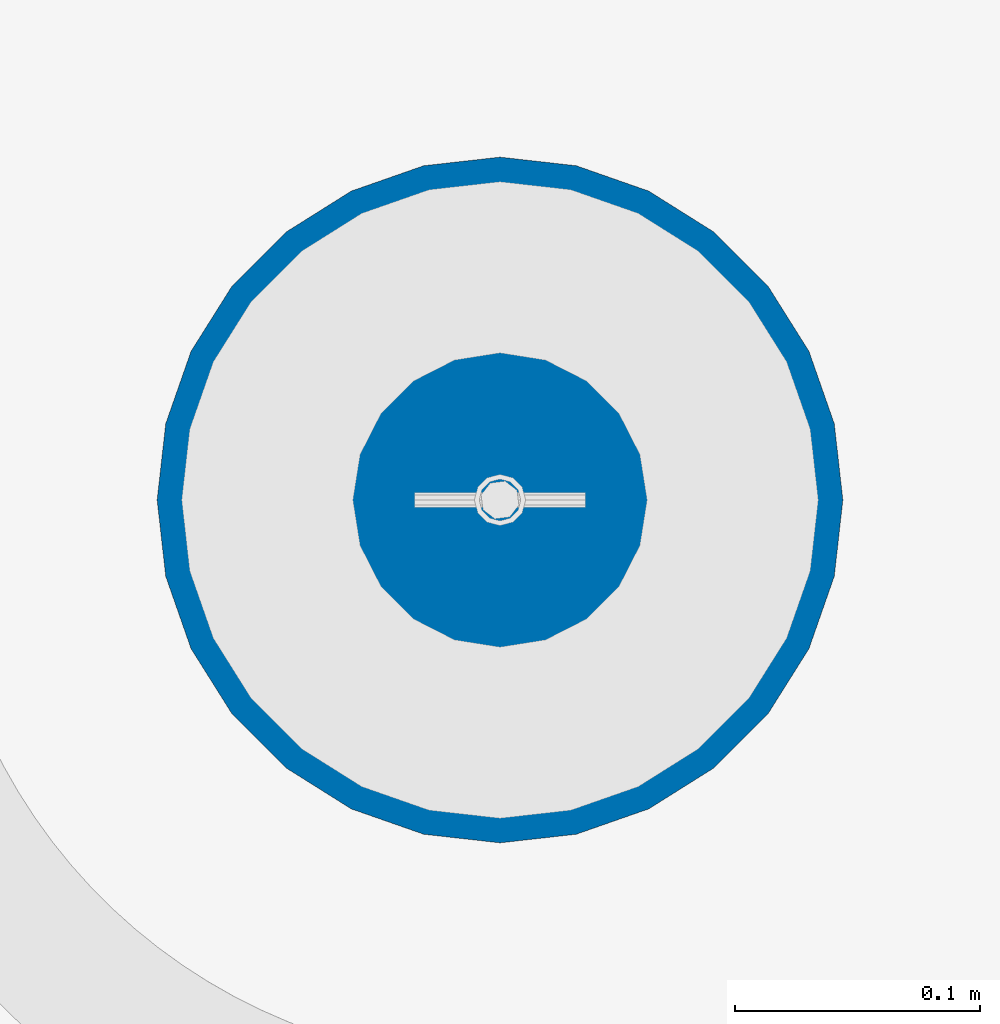
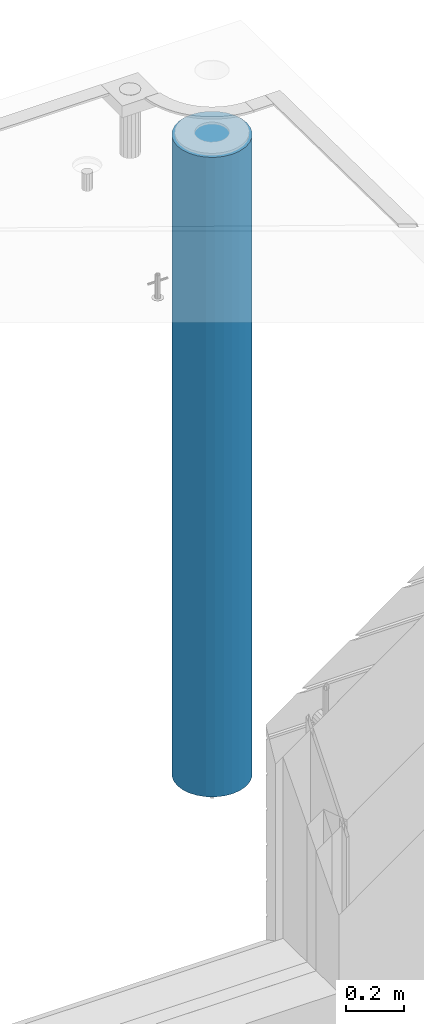
# One storey, part 7 of 350: 1 column, 1 element without a shape of its own.
"""IFC2X3 building model written with IfcOpenShell, lengths in millimetres."""

import ifcopenshell
import ifcopenshell.guid

model = None  # the IFC model being written
_history = None  # IfcOwnerHistory: only IFC2X3 demands one
_inside = {}  # id of a spatial element -> (the spatial element, [elements in it])
_under = {}  # id of a project, library or spatial element -> (it, [spatial elements below it])
_declared = {}  # id of a project -> (the project, [libraries it declares])
_typed = {}  # id of a type object -> (the type object, [elements of that type])
_made_of = {}  # id of a material, layer set ... -> (it, [elements and type objects made of it])


def new_model(schema):
    """Start an empty IFC model of exactly this schema.

    Asked for "IFC4X3", IfcOpenShell would pick the latest addendum, in which some entities
    have other attributes; the version numbers below select the first issue.
    IFC2X3 requires an IfcOwnerHistory on every rooted entity: one is made here for all.
    """
    global model, _history
    if schema == "IFC4X3":
        model = ifcopenshell.file(schema_version=(4, 3, 0, 0))
    else:
        model = ifcopenshell.file(schema=schema)
    _inside.clear()
    _under.clear()
    _declared.clear()
    _typed.clear()
    _made_of.clear()
    _history = None
    if model.schema == "IFC2X3":
        org = make("IfcOrganization", Name="unknown")
        user = make(
            "IfcPersonAndOrganization",
            ThePerson=make("IfcPerson", FamilyName="unknown"),
            TheOrganization=org,
        )
        app = make(
            "IfcApplication",
            ApplicationDeveloper=org,
            Version="unknown",
            ApplicationFullName="unknown",
            ApplicationIdentifier="unknown",
        )
        _history = make(
            "IfcOwnerHistory",
            OwningUser=user,
            OwningApplication=app,
            ChangeAction="ADDED",
            CreationDate=0,
        )
    return model


def make(cls, **values):
    """One entity of the class cls with the attributes given. An attribute that is None is left unset."""
    return model.create_entity(
        cls, **{name: value for name, value in values.items() if value is not None}
    )


def rooted(cls, **values):
    """An entity with a GlobalId (a new one), such as an element, a storey or a relation."""
    return make(cls, GlobalId=ifcopenshell.guid.new(), OwnerHistory=_history, **values)


def si_unit(unit_type, name, prefix=None):
    """IfcSIUnit, for example si_unit("LENGTHUNIT", "METRE", prefix="MILLI")."""
    return make("IfcSIUnit", UnitType=unit_type, Prefix=prefix, Name=name)


def assignment(units):
    """IfcUnitAssignment: the units of a project."""
    return None if units is None else make("IfcUnitAssignment", Units=units)


def point(xyz):
    """IfcCartesianPoint."""
    return None if xyz is None else make("IfcCartesianPoint", Coordinates=xyz)


def direction(xyz):
    """IfcDirection."""
    return None if xyz is None else make("IfcDirection", DirectionRatios=xyz)


def frame(location, z_axis=None, x_axis=None):
    """IfcAxis2Placement3D, a coordinate frame: its origin and axes. An axis left out is left unset."""
    return make(
        "IfcAxis2Placement3D",
        Location=point(location),
        Axis=direction(z_axis),
        RefDirection=direction(x_axis),
    )


def origin_with_axes():
    """The frame at (0, 0, 0) with the z axis (0, 0, 1) and the x axis (1, 0, 0) written out."""
    return frame((0.0, 0.0, 0.0), z_axis=(0.0, 0.0, 1.0), x_axis=(1.0, 0.0, 0.0))


def place(relative_to, where):
    """IfcLocalPlacement: puts the frame where relative to a parent placement (None: the world)."""
    return make(
        "IfcLocalPlacement", PlacementRelTo=relative_to, RelativePlacement=where
    )


def context(
    kind, dimensions, precision=None, world=None, true_north=None, identifier=None
):
    """IfcGeometricRepresentationContext, for example the 3D "Model" context."""
    return make(
        "IfcGeometricRepresentationContext",
        ContextIdentifier=identifier,
        ContextType=kind,
        CoordinateSpaceDimension=dimensions,
        Precision=precision,
        WorldCoordinateSystem=world,
        TrueNorth=true_north,
    )


def subcontext(parent, identifier, kind, view, scale=None):
    """IfcGeometricRepresentationSubContext, for example "Body" below "Model"."""
    return make(
        "IfcGeometricRepresentationSubContext",
        ContextIdentifier=identifier,
        ContextType=kind,
        ParentContext=parent,
        TargetScale=scale,
        TargetView=view,
    )


def project(units=None, contexts=None):
    """IfcProject with its units and contexts."""
    return rooted(
        "IfcProject",
        Name="project",
        RepresentationContexts=contexts,
        UnitsInContext=assignment(units),
    )


def spatial(cls, under=None, at=None, **own):
    """A site, building, storey or space (cls), placed at a placement, below another one or the project."""
    s = rooted(cls, ObjectPlacement=at, **own)
    if under is not None:
        _under.setdefault(under.id(), (under, []))[1].append(s)
    return s


def faces_of(points, faces, orient=None, outer=None):
    """IfcFace entities. A face is a list of loops; a loop is a list of indices into points, from 0.

    orient and outer hold one flag for each loop. By default every Orientation is true, the
    first loop of a face is its IfcFaceOuterBound and the others are IfcFaceBound.
    """
    made = []
    for i, loops in enumerate(faces):
        bounds = []
        for j, loop in enumerate(loops):
            is_outer = j == 0 if outer is None else outer[i][j]
            bounds.append(
                make(
                    "IfcFaceOuterBound" if is_outer else "IfcFaceBound",
                    Bound=make("IfcPolyLoop", Polygon=[points[k] for k in loop]),
                    Orientation=True if orient is None else orient[i][j],
                )
            )
        made.append(make("IfcFace", Bounds=bounds))
    return made


def faceted_brep(points, faces, orient=None, outer=None, voids=None):
    """IfcFacetedBrep: a solid bounded by flat faces; with voids (closed shells), ...WithVoids."""
    shared = [point(p) for p in points]
    hull = make("IfcClosedShell", CfsFaces=faces_of(shared, faces, orient, outer))
    if voids is None:
        return make("IfcFacetedBrep", Outer=hull)
    return make(
        "IfcFacetedBrepWithVoids",
        Outer=hull,
        Voids=[
            make(cls, CfsFaces=faces_of(shared, fs, o, b)) for cls, fs, o, b in voids
        ],
    )


def shape(context_of_items, identifier, shape_type, items):
    """IfcShapeRepresentation: the items that make up one representation, for example the "Body"."""
    return make(
        "IfcShapeRepresentation",
        ContextOfItems=context_of_items,
        RepresentationIdentifier=identifier,
        RepresentationType=shape_type,
        Items=items,
    )


def material(Name=None, Category=None):
    """IfcMaterial."""
    return make("IfcMaterial", Name=Name, Category=Category)


def made_of(thing, what):
    """Note that an element or type object is made of a material, layer set ...; save() writes the relation."""
    if what is not None:
        _made_of.setdefault(what.id(), (what, []))[1].append(thing)
    return thing


def type_object(cls, material=None, **own):
    """A type object (cls), such as IfcWallType, which elements share."""
    return made_of(rooted(cls, **own), material)


def element(
    cls,
    number,
    at=None,
    inside=None,
    cuts=None,
    type_object=None,
    material=None,
    context=None,
    identifier="Body",
    shape_type=None,
    held_by="IfcProductDefinitionShape",
    body=None,
    shapes=None,
    **own,
):
    """One element of the class cls, such as IfcWall. Its Tag is "e" and its number.

    at: its placement. inside: the storey or other place that contains it. cuts: it is an
    opening in that element (IfcRelVoidsElement). A single representation is given by context,
    identifier, shape_type and body (its items); several are given by shapes. held_by: the class
    of the entity that holds the representations. save() writes the other relations.
    """
    e = rooted(cls, Tag="e%d" % number, ObjectPlacement=at, **own)
    if body is not None:
        shapes = [shape(context, identifier, shape_type, body)]
    if shapes is not None:
        e.Representation = make(held_by, Representations=shapes)
    if inside is not None:
        _inside.setdefault(inside.id(), (inside, []))[1].append(e)
    if cuts is not None:
        rooted(
            "IfcRelVoidsElement", RelatingBuildingElement=cuts, RelatedOpeningElement=e
        )
    if type_object is not None:
        _typed.setdefault(type_object.id(), (type_object, []))[1].append(e)
    return made_of(e, material)


def aggregate(whole, parts):
    """IfcRelAggregates: a whole, such as a stair, and the parts it consists of."""
    return rooted("IfcRelAggregates", RelatingObject=whole, RelatedObjects=parts)


def save(model, path):
    """Write the relations noted so far, then the file.

    IfcRelAggregates (storeys below a building ...), IfcRelContainedInSpatialStructure (elements
    in a storey), IfcRelDefinesByType, IfcRelAssociatesMaterial and IfcRelDeclares: one each for
    every whole, place, type object, material and project.
    """
    for whole, parts in _under.values():
        aggregate(whole, parts)
    for where, things in _inside.values():
        rooted(
            "IfcRelContainedInSpatialStructure",
            RelatedElements=things,
            RelatingStructure=where,
        )
    for kind, things in _typed.values():
        rooted("IfcRelDefinesByType", RelatedObjects=things, RelatingType=kind)
    for what, things in _made_of.values():
        rooted("IfcRelAssociatesMaterial", RelatedObjects=things, RelatingMaterial=what)
    for by, libraries in _declared.values():
        rooted("IfcRelDeclares", RelatingContext=by, RelatedDefinitions=libraries)
    model.write(path)


model = new_model("IFC2X3")

# Units and contexts
model_context = context("Model", 3, precision=1e-05, world=origin_with_axes())
body_context = subcontext(model_context, "Body", "Model", "MODEL_VIEW")
ifc_project = project(units=[si_unit("LENGTHUNIT", "METRE", prefix="MILLI"), si_unit("AREAUNIT", "SQUARE_METRE"), si_unit("VOLUMEUNIT", "CUBIC_METRE"), si_unit("MASSUNIT", "GRAM", prefix="KILO"), si_unit("TIMEUNIT", "SECOND"), si_unit("PLANEANGLEUNIT", "RADIAN"), si_unit("SOLIDANGLEUNIT", "STERADIAN"), si_unit("THERMODYNAMICTEMPERATUREUNIT", "DEGREE_CELSIUS"), si_unit("LUMINOUSINTENSITYUNIT", "LUMEN")], contexts=[model_context])

# Site, building, storey
site_placement = place(None, origin_with_axes())
site = spatial("IfcSite", under=ifc_project, at=site_placement, CompositionType="ELEMENT")
building_placement = place(site_placement, origin_with_axes())
building = spatial("IfcBuilding", under=site, at=building_placement, CompositionType="ELEMENT")
storey_placement = place(building_placement, origin_with_axes())
storey = spatial("IfcBuildingStorey", under=building, at=storey_placement, Name="2", CompositionType="ELEMENT", Elevation=0.0)

# Assembly, column
assembly_placement = place(storey_placement, origin_with_axes())
assembly = element("IfcElementAssembly", 1, at=assembly_placement, inside=storey, AssemblyPlace="NOTDEFINED", PredefinedType="REINFORCEMENT_UNIT")
ifc_material = material(Name="CONCRETE/C30/37")
column_type = type_object("IfcColumnType", Name="D280", PredefinedType="NOTDEFINED")
column_placement = place(assembly_placement, frame((35009.9987952044, 22669.984888838, 84725.0), z_axis=(-1.0, 3.00000001838171e-08, 0.0), x_axis=(0.0, 0.0, 1.0)))
column = element("IfcColumn", 2, at=column_placement, type_object=column_type, material=ifc_material, ObjectType="D280", context=body_context, shape_type="Brep", body=[
    faceted_brep([(0.0, -140.0, 0.0), (0.0, -136.489907705454, -31.1529307538876), (2710.0, -136.489907705454, -31.1529307538876), (2710.0, -140.0, 0.0), (0.0, -126.135641506338, -60.7437234764584), (2710.0, -126.135641506338, -60.7437234764584), (0.0, -109.456407545524, -87.2885722602223), (2710.0, -109.456407545524, -87.2885722602223), (0.0, -87.2885722602223, -109.456407545527), (2710.0, -87.2885722602223, -109.456407545527), (0.0, -60.7437234764584, -126.135641506342), (2710.0, -60.7437234764584, -126.135641506342), (0.0, -31.152930753884, -136.489907705458), (2710.0, -31.152930753884, -136.489907705458), (0.0, 0.0, -140.0), (2710.0, 0.0, -140.0), (0.0, 31.152930753884, -136.489907705458), (2710.0, 31.152930753884, -136.489907705458), (0.0, 60.7437234764584, -126.135641506342), (2710.0, 60.7437234764584, -126.135641506342), (0.0, 87.2885722602223, -109.456407545527), (2710.0, 87.2885722602223, -109.456407545527), (0.0, 109.456407545524, -87.2885722602223), (2710.0, 109.456407545524, -87.2885722602223), (0.0, 126.135641506338, -60.7437234764584), (2710.0, 126.135641506338, -60.7437234764584), (0.0, 136.489907705454, -31.1529307538876), (2710.0, 136.489907705454, -31.1529307538876), (0.0, 140.0, 0.0), (2710.0, 140.0, 0.0), (0.0, 136.489907705454, 31.1529307538876), (2710.0, 136.489907705454, 31.1529307538876), (0.0, 126.135641506338, 60.7437234764584), (2710.0, 126.135641506338, 60.7437234764584), (0.0, 109.456407545524, 87.2885722602223), (2710.0, 109.456407545524, 87.2885722602223), (0.0, 87.2885722602223, 109.456407545527), (2710.0, 87.2885722602223, 109.456407545527), (0.0, 60.7437234764584, 126.135641506342), (2710.0, 60.7437234764584, 126.135641506342), (0.0, 31.152930753884, 136.489907705458), (2710.0, 31.152930753884, 136.489907705458), (0.0, 0.0, 140.0), (2710.0, 0.0, 140.0), (0.0, -31.152930753884, 136.489907705458), (2710.0, -31.152930753884, 136.489907705458), (0.0, -60.7437234764584, 126.135641506342), (2710.0, -60.7437234764584, 126.135641506342), (0.0, -87.2885722602223, 109.456407545527), (2710.0, -87.2885722602223, 109.456407545527), (0.0, -109.456407545524, 87.2885722602223), (2710.0, -109.456407545524, 87.2885722602223), (0.0, -126.135641506338, 60.7437234764584), (2710.0, -126.135641506338, 60.7437234764584), (0.0, -136.489907705454, 31.1529307538876), (2710.0, -136.489907705454, 31.1529307538876)], [[[0, 1, 2, 3]], [[1, 4, 5, 2]], [[4, 6, 7, 5]], [[6, 8, 9, 7]], [[8, 10, 11, 9]], [[10, 12, 13, 11]], [[12, 14, 15, 13]], [[14, 16, 17, 15]], [[16, 18, 19, 17]], [[18, 20, 21, 19]], [[20, 22, 23, 21]], [[22, 24, 25, 23]], [[24, 26, 27, 25]], [[26, 28, 29, 27]], [[28, 30, 31, 29]], [[30, 32, 33, 31]], [[32, 34, 35, 33]], [[34, 36, 37, 35]], [[36, 38, 39, 37]], [[38, 40, 41, 39]], [[40, 42, 43, 41]], [[42, 44, 45, 43]], [[44, 46, 47, 45]], [[46, 48, 49, 47]], [[48, 50, 51, 49]], [[50, 52, 53, 51]], [[52, 54, 55, 53]], [[54, 0, 3, 55]], [[5, 7, 9, 11, 13, 15, 17, 19, 21, 23, 25, 27, 29, 31, 33, 35, 37, 39, 41, 43, 45, 47, 49, 51, 53, 55, 3, 2]], [[54, 52, 50, 48, 46, 44, 42, 40, 38, 36, 34, 32, 30, 28, 26, 24, 22, 20, 18, 16, 14, 12, 10, 8, 6, 4, 1, 0]]]),
])
aggregate(assembly, [column])

save(model, "model.ifc")
